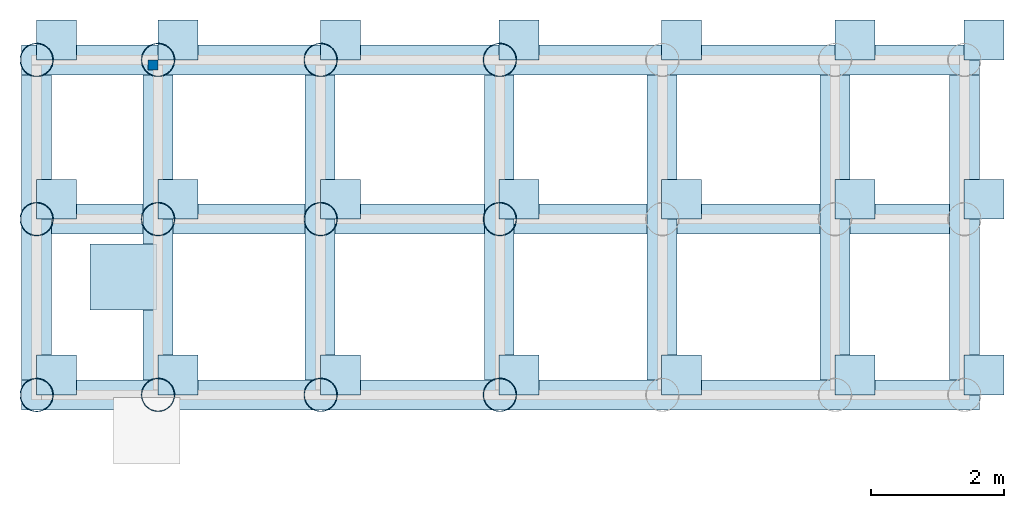
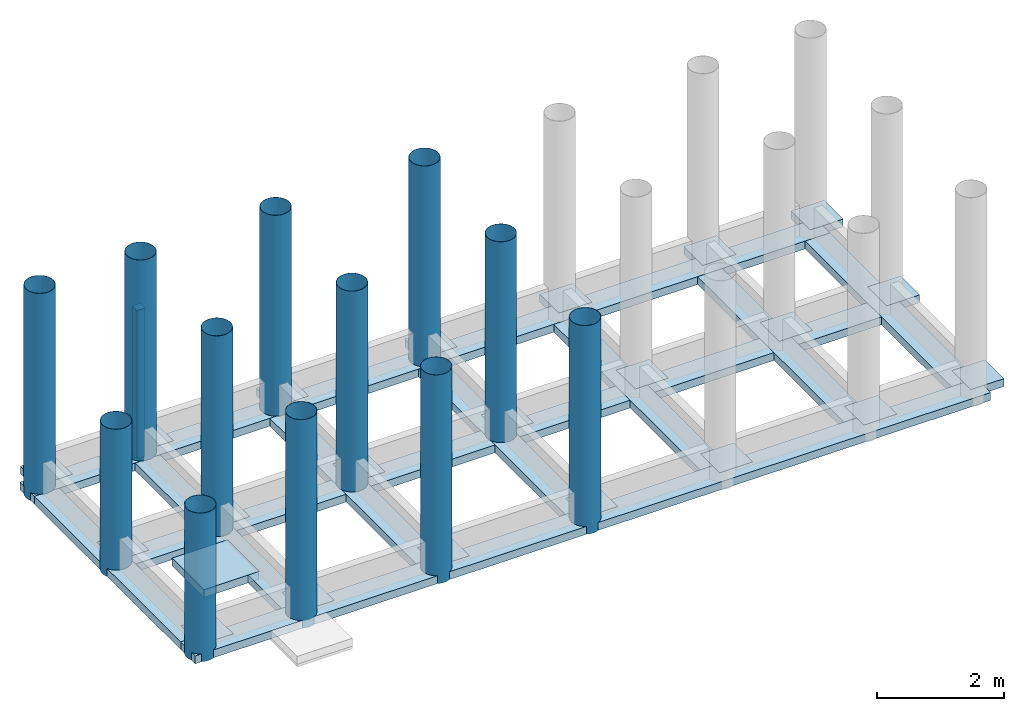
# One storey, part 1 of 2: 33 footings, 13 columns.
"""IFC4 building model written with IfcOpenShell, lengths in millimetres."""

from ifc_helpers import new_model, entity, si_unit, converted_unit, frame, origin_with_axes, origin_2d_with_axis, place, context, subcontext, project, spatial, line, indexed_curve, rectangle, hollow_circle, outline, extrude, material, layer, layer_set, layer_usage, material_profile, profile_set, profile_usage, type_object, element, save


model = new_model("IFC4")

# Units and contexts
model_context = context("Model", 3, precision=1e-05, world=origin_with_axes())
plan_context = context("Plan", 2, precision=1e-05, world=origin_2d_with_axis())
body_context = subcontext(model_context, "Body", "Model", "MODEL_VIEW")
ifc_project = project(units=[si_unit("AREAUNIT", "SQUARE_METRE"), si_unit("VOLUMEUNIT", "CUBIC_METRE"), si_unit("LENGTHUNIT", "METRE", prefix="MILLI"), converted_unit("PLANEANGLEUNIT", "degree", entity("IfcReal", 0.0174532925199433), si_unit("PLANEANGLEUNIT", "RADIAN"), dimensions=[0, 0, 0, 0, 0, 0, 0])], contexts=[model_context, plan_context])

# Site, building, storey
site_placement = place(None, frame((-860.053181648254, 6515.22541046143, 2.98023223876953e-05), z_axis=(0.0, 0.0, 1.0), x_axis=(7.54979012640431e-08, -0.999999999999997, 0.0)))
site = spatial("IfcSite", under=ifc_project, at=site_placement)
building_placement = place(site_placement, frame((0.0, 0.0, 0.0), z_axis=(0.0, 0.0, 1.0), x_axis=(1.0, -1.32348898008484e-23, 0.0)))
building = spatial("IfcBuilding", under=site, at=building_placement, Name="Building")
storey_placement = place(building_placement, frame((0.222206115722656, -1.67760250135984e-08, -750.000089406967), z_axis=(0.0, 0.0, 1.0), x_axis=(7.54979012640431e-08, 0.999999999999997, 0.0)))
storey = spatial("IfcBuildingStorey", under=building, at=storey_placement, Name="FOUNDATION")

# Footings
ifc_material = material(Name="Mass Concrete", Category="Concrete")
ifc_layer_1 = layer(ifc_material, 150.0, Name="Footing Layer", Category="Structure", Priority=1)
ifc_layer_set_1 = layer_set([ifc_layer_1], Name="WALL_FND_FTG_1LYR")
ifc_layer_usage_1 = layer_usage(ifc_layer_set_1, "AXIS3", "POSITIVE", 0.0)
footing_type = type_object("IfcFootingType", Name="FTG450x150", PredefinedType="STRIP_FOOTING", material=ifc_layer_set_1)
footing_1_placement = place(storey_placement, frame((124.997615814208, -549.653530120853, -149.999976158142), z_axis=(0.0, 0.0, 1.0), x_axis=(1.0, 1.32348898008484e-23, 0.0)))
element("IfcFooting", 1, at=footing_1_placement, inside=storey, type_object=footing_type, material=ifc_layer_usage_1, PredefinedType="STRIP_FOOTING", context=body_context, shape_type="SweptSolid", body=[
    extrude(outline(indexed_curve([(14205.0037384033, 149.991720914841), (14205.0037384033, -300.007820129395), (-225.000858306885, -300.007820129395), (-225.000858306885, 149.991720914841)], segments=[line(3, 2), line(2, 1), line(1, 4), line(4, 3)], self_intersect=False)), None, (0.0, 0.0, 1.0), 150.0),
])
ifc_layer_usage_2 = layer_usage(ifc_layer_set_1, "AXIS3", "POSITIVE", 0.0)
footing_2_placement = place(storey_placement, frame((124.997615814208, -2949.6774673462, -149.999976158142), z_axis=(0.0, 0.0, 1.0), x_axis=(1.0, 1.32348898008484e-23, 0.0)))
element("IfcFooting", 2, at=footing_2_placement, inside=storey, type_object=footing_type, material=ifc_layer_usage_2, Name="FLR150", PredefinedType="STRIP_FOOTING", context=body_context, shape_type="SweptSolid", body=[
    extrude(outline(indexed_curve([(13755.0058364868, 149.991720914841), (13755.0058364868, -300.007820129395), (224.997639656067, -300.007820129395), (224.997639656067, 149.991720914841)], segments=[line(3, 2), line(2, 1), line(1, 4), line(4, 3)], self_intersect=False)), None, (0.0, 0.0, 1.0), 150.0),
])
ifc_layer_usage_3 = layer_usage(ifc_layer_set_1, "AXIS3", "POSITIVE", 0.0)
footing_3_placement = place(storey_placement, frame((49.9976277351375, -5898.65279197693, -149.999976158142), z_axis=(0.0, 0.0, 1.0), x_axis=(1.0, 1.32348898008484e-23, 0.0)))
element("IfcFooting", 3, at=footing_3_placement, inside=storey, type_object=footing_type, material=ifc_layer_usage_3, PredefinedType="STRIP_FOOTING", context=body_context, shape_type="SweptSolid", body=[
    extrude(outline(indexed_curve([(299.997597932816, 5048.99168014526), (299.997597932816, 449.19490814209), (-150.000870227814, 449.19490814209), (-150.000870227814, 5048.99168014526)], segments=[line(3, 2), line(2, 1), line(1, 4), line(4, 3)], self_intersect=False)), None, (0.0, 0.0, 1.0), 150.0),
])
ifc_layer_usage_4 = layer_usage(ifc_layer_set_1, "AXIS3", "POSITIVE", 0.0)
footing_4_placement = place(storey_placement, frame((1880.00190258026, -5898.65279197693, -149.999976158142), z_axis=(0.0, 0.0, 1.0), x_axis=(1.0, 1.32348898008484e-23, 0.0)))
element("IfcFooting", 4, at=footing_4_placement, inside=storey, type_object=footing_type, material=ifc_layer_usage_4, PredefinedType="STRIP_FOOTING", context=body_context, shape_type="SweptSolid", body=[
    extrude(outline(indexed_curve([(299.997597932816, 5048.99168014526), (299.997597932816, 449.999570846558), (-150.000870227814, 449.999570846558), (-150.000870227814, 5048.99168014526)], segments=[line(3, 2), line(2, 1), line(1, 4), line(4, 3)], self_intersect=False)), None, (0.0, 0.0, 1.0), 150.0),
])
ifc_layer_usage_5 = layer_usage(ifc_layer_set_1, "AXIS3", "POSITIVE", 0.0)
footing_5_placement = place(storey_placement, frame((4320.84238529205, -5898.65279197693, -149.999976158142), z_axis=(0.0, 0.0, 1.0), x_axis=(1.0, 1.32348898008484e-23, 0.0)))
element("IfcFooting", 5, at=footing_5_placement, inside=storey, type_object=footing_type, material=ifc_layer_usage_5, PredefinedType="STRIP_FOOTING", context=body_context, shape_type="SweptSolid", body=[
    extrude(outline(indexed_curve([(-150.000870227814, 449.999570846558), (299.997597932816, 449.999570846558), (299.997597932816, 5048.99168014526), (-150.000870227814, 5048.99168014526)], segments=[line(3, 2), line(2, 1), line(1, 4), line(4, 3)], self_intersect=False)), None, (0.0, 0.0, 1.0), 150.0),
])
ifc_layer_usage_6 = layer_usage(ifc_layer_set_1, "AXIS3", "POSITIVE", 0.0)
footing_6_placement = place(storey_placement, frame((7020.84076404571, -5898.65279197693, -149.999976158142), z_axis=(0.0, 0.0, 1.0), x_axis=(1.0, 1.32348898008484e-23, 0.0)))
element("IfcFooting", 6, at=footing_6_placement, inside=storey, type_object=footing_type, material=ifc_layer_usage_6, PredefinedType="STRIP_FOOTING", context=body_context, shape_type="SweptSolid", body=[
    extrude(outline(indexed_curve([(-150.000870227814, 449.999570846558), (299.997597932816, 449.999570846558), (299.997597932816, 5048.99168014526), (-150.000870227814, 5048.99168014526)], segments=[line(3, 2), line(2, 1), line(1, 4), line(4, 3)], self_intersect=False)), None, (0.0, 0.0, 1.0), 150.0),
])
ifc_layer_usage_7 = layer_usage(ifc_layer_set_1, "AXIS3", "POSITIVE", 0.0)
footing_7_placement = place(storey_placement, frame((9470.83961963653, -5898.65279197693, -149.999976158142), z_axis=(0.0, 0.0, 1.0), x_axis=(1.0, 1.32348898008484e-23, 0.0)))
element("IfcFooting", 7, at=footing_7_placement, inside=storey, type_object=footing_type, material=ifc_layer_usage_7, PredefinedType="STRIP_FOOTING", context=body_context, shape_type="SweptSolid", body=[
    extrude(outline(indexed_curve([(-150.000870227814, 449.999570846558), (299.997597932816, 449.999570846558), (299.997597932816, 5048.99168014526), (-150.000870227814, 5048.99168014526)], segments=[line(3, 2), line(2, 1), line(1, 4), line(4, 3)], self_intersect=False)), None, (0.0, 0.0, 1.0), 150.0),
])
ifc_layer_usage_8 = layer_usage(ifc_layer_set_1, "AXIS3", "POSITIVE", 0.0)
footing_8_placement = place(storey_placement, frame((12080.0048112869, -5898.65279197693, -149.999976158142), z_axis=(0.0, 0.0, 1.0), x_axis=(1.0, 1.32348898008484e-23, 0.0)))
element("IfcFooting", 8, at=footing_8_placement, inside=storey, type_object=footing_type, material=ifc_layer_usage_8, PredefinedType="STRIP_FOOTING", context=body_context, shape_type="SweptSolid", body=[
    extrude(outline(indexed_curve([(-150.000870227814, 449.999570846558), (299.997597932816, 449.999570846558), (299.997597932816, 5048.99168014526), (-150.000870227814, 5048.99168014526)], segments=[line(3, 2), line(2, 1), line(1, 4), line(4, 3)], self_intersect=False)), None, (0.0, 0.0, 1.0), 150.0),
])
ifc_layer_usage_9 = layer_usage(ifc_layer_set_1, "AXIS3", "POSITIVE", 0.0)
footing_9_placement = place(storey_placement, frame((14030.0036668777, -5898.65279197693, -149.999976158142), z_axis=(0.0, 0.0, 1.0), x_axis=(1.0, 1.32348898008484e-23, 0.0)))
element("IfcFooting", 9, at=footing_9_placement, inside=storey, type_object=footing_type, material=ifc_layer_usage_9, Name="FLR150", PredefinedType="STRIP_FOOTING", context=body_context, shape_type="SweptSolid", body=[
    extrude(outline(indexed_curve([(-150.000870227814, 449.999570846558), (299.997597932816, 449.999570846558), (299.997597932816, 5048.99168014526), (-150.000870227814, 5048.99168014526)], segments=[line(3, 2), line(2, 1), line(1, 4), line(4, 3)], self_intersect=False)), None, (0.0, 0.0, 1.0), 150.0),
])
ifc_layer_usage_10 = layer_usage(ifc_layer_set_1, "AXIS3", "POSITIVE", 0.0)
footing_10_placement = place(storey_placement, frame((124.997615814208, -5599.449634552, -149.999976158142), z_axis=(0.0, 0.0, 1.0), x_axis=(1.0, 1.32348898008484e-23, 0.0)))
element("IfcFooting", 10, at=footing_10_placement, inside=storey, type_object=footing_type, material=ifc_layer_usage_10, PredefinedType="STRIP_FOOTING", context=body_context, shape_type="SweptSolid", body=[
    extrude(outline(indexed_curve([(-225.000858306885, -300.007820129395), (14205.0037384033, -300.007820129395), (14205.0037384033, 149.991720914841), (-225.000858306885, 149.991720914841)], segments=[line(3, 2), line(2, 1), line(1, 4), line(4, 3)], self_intersect=False)), None, (0.0, 0.0, 1.0), 150.0),
])
ifc_layer_usage_11 = layer_usage(ifc_layer_set_1, "AXIS2", "POSITIVE", 0.0)
footing_11_placement = place(storey_placement, frame((929.933577775955, -4396.21543884278, -149.999976158142), z_axis=(0.0, 0.0, 1.0), x_axis=(1.0, 1.32348898008484e-23, 0.0)))
element("IfcFooting", 11, at=footing_11_placement, inside=storey, type_object=footing_type, material=ifc_layer_usage_11, Name="FTG450x150", context=body_context, shape_type="SweptSolid", body=[
    extrude(outline(indexed_curve([(0.0, 0.0), (1000.0, 0.0), (1000.0, 1000.0), (0.0, 1000.0), (0.0, 0.0)])), None, (0.0, 0.0, 1.0), 150.0),
])
ifc_layer_usage_12 = layer_usage(ifc_layer_set_1, "AXIS2", "POSITIVE", 0.0)
footing_12_placement = place(storey_placement, frame((929.933577775955, -4396.21543884278, -149.999976158142), z_axis=(0.0, 0.0, 1.0), x_axis=(1.0, 1.32348898008484e-23, 0.0)))
element("IfcFooting", 12, at=footing_12_placement, inside=storey, type_object=footing_type, material=ifc_layer_usage_12, Name="FTG450x150", context=body_context, shape_type="SweptSolid", body=[
    extrude(outline(indexed_curve([(0.0, 0.0), (1000.0, 0.0), (1000.0, 1000.0), (0.0, 1000.0), (0.0, 0.0)])), None, (0.0, 0.0, 1.0), 150.0),
])
ifc_layer_2 = layer(ifc_material, 150.0, Name="Column Footing Layer", Category="Structure", Priority=1)
ifc_layer_set_2 = layer_set([ifc_layer_2], Name="FTG_COL_1LYR")
ifc_layer_usage_13 = layer_usage(ifc_layer_set_2, "AXIS3", "POSITIVE", 0.0)
slab_type = type_object("IfcSlabType", Name="FLR_150", PredefinedType="NOTDEFINED", material=ifc_layer_set_2)
footing_13_placement = place(storey_placement, frame((124.994397163391, -5674.44968223572, -149.999976158142), z_axis=(0.0, 0.0, 1.0), x_axis=(1.0, 1.32348898008484e-23, 0.0)))
element("IfcFooting", 13, at=footing_13_placement, inside=storey, type_object=slab_type, material=ifc_layer_usage_13, PredefinedType="PAD_FOOTING", context=body_context, shape_type="SweptSolid", body=[
    extrude(outline(indexed_curve([(0.0, 0.0), (600.000023841858, 0.0), (600.000023841858, 600.000023841858), (0.0, 600.000023841858)], segments=[line(3, 2), line(2, 1), line(1, 4), line(4, 3)], self_intersect=False)), None, (0.0, 0.0, 1.0), 150.0),
])
ifc_layer_usage_14 = layer_usage(ifc_layer_set_2, "AXIS3", "POSITIVE", 0.0)
footing_14_placement = place(storey_placement, frame((124.994397163391, -3024.6856212616, -149.999976158142), z_axis=(0.0, 0.0, 1.0), x_axis=(1.0, 1.32348898008484e-23, 0.0)))
element("IfcFooting", 14, at=footing_14_placement, inside=storey, type_object=slab_type, material=ifc_layer_usage_14, PredefinedType="PAD_FOOTING", context=body_context, shape_type="SweptSolid", body=[
    extrude(outline(indexed_curve([(0.0, 0.0), (600.000023841858, 0.0), (600.000023841858, 600.000023841858), (0.0, 600.000023841858)], segments=[line(3, 2), line(2, 1), line(1, 4), line(4, 3)], self_intersect=False)), None, (0.0, 0.0, 1.0), 150.0),
])
ifc_layer_usage_15 = layer_usage(ifc_layer_set_2, "AXIS3", "POSITIVE", 0.0)
footing_15_placement = place(storey_placement, frame((124.994397163391, -624.653816223148, -149.999976158142), z_axis=(0.0, 0.0, 1.0), x_axis=(1.0, 1.32348898008484e-23, 0.0)))
element("IfcFooting", 15, at=footing_15_placement, inside=storey, type_object=slab_type, material=ifc_layer_usage_15, PredefinedType="PAD_FOOTING", context=body_context, shape_type="SweptSolid", body=[
    extrude(outline(indexed_curve([(0.0, 0.0), (600.000023841858, 0.0), (600.000023841858, 600.000023841858), (0.0, 600.000023841858)], segments=[line(3, 2), line(2, 1), line(1, 4), line(4, 3)], self_intersect=False)), None, (0.0, 0.0, 1.0), 150.0),
])
ifc_layer_usage_16 = layer_usage(ifc_layer_set_2, "AXIS3", "POSITIVE", 0.0)
footing_16_placement = place(storey_placement, frame((1956.27570152283, -5674.44968223572, -149.999976158142), z_axis=(0.0, 0.0, 1.0), x_axis=(1.0, 1.32348898008484e-23, 0.0)))
element("IfcFooting", 16, at=footing_16_placement, inside=storey, type_object=slab_type, material=ifc_layer_usage_16, PredefinedType="PAD_FOOTING", context=body_context, shape_type="SweptSolid", body=[
    extrude(outline(indexed_curve([(0.0, 0.0), (600.000023841858, 0.0), (600.000023841858, 600.000023841858), (0.0, 600.000023841858)], segments=[line(3, 2), line(2, 1), line(1, 4), line(4, 3)], self_intersect=False)), None, (0.0, 0.0, 1.0), 150.0),
])
ifc_layer_usage_17 = layer_usage(ifc_layer_set_2, "AXIS3", "POSITIVE", 0.0)
footing_17_placement = place(storey_placement, frame((1956.27570152283, -3024.6856212616, -149.999976158142), z_axis=(0.0, 0.0, 1.0), x_axis=(1.0, 1.32348898008484e-23, 0.0)))
element("IfcFooting", 17, at=footing_17_placement, inside=storey, type_object=slab_type, material=ifc_layer_usage_17, PredefinedType="PAD_FOOTING", context=body_context, shape_type="SweptSolid", body=[
    extrude(outline(indexed_curve([(0.0, 0.0), (600.000023841858, 0.0), (600.000023841858, 600.000023841858), (0.0, 600.000023841858)], segments=[line(3, 2), line(2, 1), line(1, 4), line(4, 3)], self_intersect=False)), None, (0.0, 0.0, 1.0), 150.0),
])
ifc_layer_usage_18 = layer_usage(ifc_layer_set_2, "AXIS3", "POSITIVE", 0.0)
footing_18_placement = place(storey_placement, frame((1956.27570152283, -624.653816223148, -149.999976158142), z_axis=(0.0, 0.0, 1.0), x_axis=(1.0, 1.32348898008484e-23, 0.0)))
element("IfcFooting", 18, at=footing_18_placement, inside=storey, type_object=slab_type, material=ifc_layer_usage_18, PredefinedType="PAD_FOOTING", context=body_context, shape_type="SweptSolid", body=[
    extrude(outline(indexed_curve([(0.0, 0.0), (600.000023841858, 0.0), (600.000023841858, 600.000023841858), (0.0, 600.000023841858)], segments=[line(3, 2), line(2, 1), line(1, 4), line(4, 3)], self_intersect=False)), None, (0.0, 0.0, 1.0), 150.0),
])
ifc_layer_usage_19 = layer_usage(ifc_layer_set_2, "AXIS3", "POSITIVE", 0.0)
footing_19_placement = place(storey_placement, frame((4405.00128269195, -5674.44968223572, -149.999976158142), z_axis=(0.0, 0.0, 1.0), x_axis=(1.0, 1.32348898008484e-23, 0.0)))
element("IfcFooting", 19, at=footing_19_placement, inside=storey, type_object=slab_type, material=ifc_layer_usage_19, PredefinedType="PAD_FOOTING", context=body_context, shape_type="SweptSolid", body=[
    extrude(outline(indexed_curve([(0.0, 0.0), (600.000023841858, 0.0), (600.000023841858, 600.000023841858), (0.0, 600.000023841858)], segments=[line(3, 2), line(2, 1), line(1, 4), line(4, 3)], self_intersect=False)), None, (0.0, 0.0, 1.0), 150.0),
])
ifc_layer_usage_20 = layer_usage(ifc_layer_set_2, "AXIS3", "POSITIVE", 0.0)
footing_20_placement = place(storey_placement, frame((4405.00128269195, -3024.6856212616, -149.999976158142), z_axis=(0.0, 0.0, 1.0), x_axis=(1.0, 1.32348898008484e-23, 0.0)))
element("IfcFooting", 20, at=footing_20_placement, inside=storey, type_object=slab_type, material=ifc_layer_usage_20, PredefinedType="PAD_FOOTING", context=body_context, shape_type="SweptSolid", body=[
    extrude(outline(indexed_curve([(0.0, 0.0), (600.000023841858, 0.0), (600.000023841858, 600.000023841858), (0.0, 600.000023841858)], segments=[line(3, 2), line(2, 1), line(1, 4), line(4, 3)], self_intersect=False)), None, (0.0, 0.0, 1.0), 150.0),
])
ifc_layer_usage_21 = layer_usage(ifc_layer_set_2, "AXIS3", "POSITIVE", 0.0)
footing_21_placement = place(storey_placement, frame((4405.00128269195, -624.653816223148, -149.999976158142), z_axis=(0.0, 0.0, 1.0), x_axis=(1.0, 1.32348898008484e-23, 0.0)))
element("IfcFooting", 21, at=footing_21_placement, inside=storey, type_object=slab_type, material=ifc_layer_usage_21, PredefinedType="PAD_FOOTING", context=body_context, shape_type="SweptSolid", body=[
    extrude(outline(indexed_curve([(0.0, 0.0), (600.000023841858, 0.0), (600.000023841858, 600.000023841858), (0.0, 600.000023841858)], segments=[line(3, 2), line(2, 1), line(1, 4), line(4, 3)], self_intersect=False)), None, (0.0, 0.0, 1.0), 150.0),
])
ifc_layer_usage_22 = layer_usage(ifc_layer_set_2, "AXIS3", "POSITIVE", 0.0)
footing_22_placement = place(storey_placement, frame((7095.83914279937, -5674.44968223572, -149.999976158142), z_axis=(0.0, 0.0, 1.0), x_axis=(1.0, 1.32348898008484e-23, 0.0)))
element("IfcFooting", 22, at=footing_22_placement, inside=storey, type_object=slab_type, material=ifc_layer_usage_22, PredefinedType="PAD_FOOTING", context=body_context, shape_type="SweptSolid", body=[
    extrude(outline(indexed_curve([(0.0, 0.0), (600.000023841858, 0.0), (600.000023841858, 600.000023841858), (0.0, 600.000023841858)], segments=[line(3, 2), line(2, 1), line(1, 4), line(4, 3)], self_intersect=False)), None, (0.0, 0.0, 1.0), 150.0),
])
ifc_layer_usage_23 = layer_usage(ifc_layer_set_2, "AXIS3", "POSITIVE", 0.0)
footing_23_placement = place(storey_placement, frame((7095.83914279937, -3024.6856212616, -149.999976158142), z_axis=(0.0, 0.0, 1.0), x_axis=(1.0, 1.32348898008484e-23, 0.0)))
element("IfcFooting", 23, at=footing_23_placement, inside=storey, type_object=slab_type, material=ifc_layer_usage_23, PredefinedType="PAD_FOOTING", context=body_context, shape_type="SweptSolid", body=[
    extrude(outline(indexed_curve([(0.0, 0.0), (600.000023841858, 0.0), (600.000023841858, 600.000023841858), (0.0, 600.000023841858)], segments=[line(3, 2), line(2, 1), line(1, 4), line(4, 3)], self_intersect=False)), None, (0.0, 0.0, 1.0), 150.0),
])
ifc_layer_usage_24 = layer_usage(ifc_layer_set_2, "AXIS3", "POSITIVE", 0.0)
footing_24_placement = place(storey_placement, frame((7095.83914279937, -624.653816223148, -149.999976158142), z_axis=(0.0, 0.0, 1.0), x_axis=(1.0, 1.32348898008484e-23, 0.0)))
element("IfcFooting", 24, at=footing_24_placement, inside=storey, type_object=slab_type, material=ifc_layer_usage_24, PredefinedType="PAD_FOOTING", context=body_context, shape_type="SweptSolid", body=[
    extrude(outline(indexed_curve([(0.0, 0.0), (600.000023841858, 0.0), (600.000023841858, 600.000023841858), (0.0, 600.000023841858)], segments=[line(3, 2), line(2, 1), line(1, 4), line(4, 3)], self_intersect=False)), None, (0.0, 0.0, 1.0), 150.0),
])
ifc_layer_usage_25 = layer_usage(ifc_layer_set_2, "AXIS3", "POSITIVE", 0.0)
footing_25_placement = place(storey_placement, frame((9541.80443286896, -5674.44968223572, -149.999976158142), z_axis=(0.0, 0.0, 1.0), x_axis=(1.0, 1.32348898008484e-23, 0.0)))
element("IfcFooting", 25, at=footing_25_placement, inside=storey, type_object=slab_type, material=ifc_layer_usage_25, PredefinedType="PAD_FOOTING", context=body_context, shape_type="SweptSolid", body=[
    extrude(outline(indexed_curve([(0.0, 0.0), (600.000023841858, 0.0), (600.000023841858, 600.000023841858), (0.0, 600.000023841858)], segments=[line(3, 2), line(2, 1), line(1, 4), line(4, 3)], self_intersect=False)), None, (0.0, 0.0, 1.0), 150.0),
])
ifc_layer_usage_26 = layer_usage(ifc_layer_set_2, "AXIS3", "POSITIVE", 0.0)
footing_26_placement = place(storey_placement, frame((9541.80443286896, -3024.6856212616, -149.999976158142), z_axis=(0.0, 0.0, 1.0), x_axis=(1.0, 1.32348898008484e-23, 0.0)))
element("IfcFooting", 26, at=footing_26_placement, inside=storey, type_object=slab_type, material=ifc_layer_usage_26, PredefinedType="PAD_FOOTING", context=body_context, shape_type="SweptSolid", body=[
    extrude(outline(indexed_curve([(0.0, 0.0), (600.000023841858, 0.0), (600.000023841858, 600.000023841858), (0.0, 600.000023841858)], segments=[line(3, 2), line(2, 1), line(1, 4), line(4, 3)], self_intersect=False)), None, (0.0, 0.0, 1.0), 150.0),
])
ifc_layer_usage_27 = layer_usage(ifc_layer_set_2, "AXIS3", "POSITIVE", 0.0)
footing_27_placement = place(storey_placement, frame((9541.80443286896, -624.653816223148, -149.999976158142), z_axis=(0.0, 0.0, 1.0), x_axis=(1.0, 1.32348898008484e-23, 0.0)))
element("IfcFooting", 27, at=footing_27_placement, inside=storey, type_object=slab_type, material=ifc_layer_usage_27, PredefinedType="PAD_FOOTING", context=body_context, shape_type="SweptSolid", body=[
    extrude(outline(indexed_curve([(0.0, 0.0), (600.000023841858, 0.0), (600.000023841858, 600.000023841858), (0.0, 600.000023841858)], segments=[line(3, 2), line(2, 1), line(1, 4), line(4, 3)], self_intersect=False)), None, (0.0, 0.0, 1.0), 150.0),
])
ifc_layer_usage_28 = layer_usage(ifc_layer_set_2, "AXIS3", "POSITIVE", 0.0)
footing_28_placement = place(storey_placement, frame((12156.2777757645, -5674.44968223572, -149.999976158142), z_axis=(0.0, 0.0, 1.0), x_axis=(1.0, 1.32348898008484e-23, 0.0)))
element("IfcFooting", 28, at=footing_28_placement, inside=storey, type_object=slab_type, material=ifc_layer_usage_28, PredefinedType="PAD_FOOTING", context=body_context, shape_type="SweptSolid", body=[
    extrude(outline(indexed_curve([(0.0, 0.0), (600.000023841858, 0.0), (600.000023841858, 600.000023841858), (0.0, 600.000023841858)], segments=[line(3, 2), line(2, 1), line(1, 4), line(4, 3)], self_intersect=False)), None, (0.0, 0.0, 1.0), 150.0),
])
ifc_layer_usage_29 = layer_usage(ifc_layer_set_2, "AXIS3", "POSITIVE", 0.0)
footing_29_placement = place(storey_placement, frame((12156.2777757645, -3024.6856212616, -149.999976158142), z_axis=(0.0, 0.0, 1.0), x_axis=(1.0, 1.32348898008484e-23, 0.0)))
element("IfcFooting", 29, at=footing_29_placement, inside=storey, type_object=slab_type, material=ifc_layer_usage_29, PredefinedType="PAD_FOOTING", context=body_context, shape_type="SweptSolid", body=[
    extrude(outline(indexed_curve([(0.0, 0.0), (600.000023841858, 0.0), (600.000023841858, 600.000023841858), (0.0, 600.000023841858)], segments=[line(3, 2), line(2, 1), line(1, 4), line(4, 3)], self_intersect=False)), None, (0.0, 0.0, 1.0), 150.0),
])
ifc_layer_usage_30 = layer_usage(ifc_layer_set_2, "AXIS3", "POSITIVE", 0.0)
footing_30_placement = place(storey_placement, frame((12156.2777757645, -624.653816223148, -149.999976158142), z_axis=(0.0, 0.0, 1.0), x_axis=(1.0, 1.32348898008484e-23, 0.0)))
element("IfcFooting", 30, at=footing_30_placement, inside=storey, type_object=slab_type, material=ifc_layer_usage_30, PredefinedType="PAD_FOOTING", context=body_context, shape_type="SweptSolid", body=[
    extrude(outline(indexed_curve([(0.0, 0.0), (600.000023841858, 0.0), (600.000023841858, 600.000023841858), (0.0, 600.000023841858)], segments=[line(3, 2), line(2, 1), line(1, 4), line(4, 3)], self_intersect=False)), None, (0.0, 0.0, 1.0), 150.0),
])
ifc_layer_usage_31 = layer_usage(ifc_layer_set_2, "AXIS3", "POSITIVE", 0.0)
footing_31_placement = place(storey_placement, frame((14100.9684801102, -5674.44968223572, -149.999976158142), z_axis=(0.0, 0.0, 1.0), x_axis=(1.0, 1.32348898008484e-23, 0.0)))
element("IfcFooting", 31, at=footing_31_placement, inside=storey, type_object=slab_type, material=ifc_layer_usage_31, PredefinedType="PAD_FOOTING", context=body_context, shape_type="SweptSolid", body=[
    extrude(outline(indexed_curve([(0.0, 0.0), (600.000023841858, 0.0), (600.000023841858, 600.000023841858), (0.0, 600.000023841858)], segments=[line(3, 2), line(2, 1), line(1, 4), line(4, 3)], self_intersect=False)), None, (0.0, 0.0, 1.0), 150.0),
])
ifc_layer_usage_32 = layer_usage(ifc_layer_set_2, "AXIS3", "POSITIVE", 0.0)
footing_32_placement = place(storey_placement, frame((14100.9684801102, -3024.6856212616, -149.999976158142), z_axis=(0.0, 0.0, 1.0), x_axis=(1.0, 1.32348898008484e-23, 0.0)))
element("IfcFooting", 32, at=footing_32_placement, inside=storey, type_object=slab_type, material=ifc_layer_usage_32, PredefinedType="PAD_FOOTING", context=body_context, shape_type="SweptSolid", body=[
    extrude(outline(indexed_curve([(0.0, 0.0), (600.000023841858, 0.0), (600.000023841858, 600.000023841858), (0.0, 600.000023841858)], segments=[line(3, 2), line(2, 1), line(1, 4), line(4, 3)], self_intersect=False)), None, (0.0, 0.0, 1.0), 150.0),
])
ifc_layer_usage_33 = layer_usage(ifc_layer_set_2, "AXIS3", "POSITIVE", 0.0)
footing_33_placement = place(storey_placement, frame((14100.9684801102, -624.653816223148, -149.999976158142), z_axis=(0.0, 0.0, 1.0), x_axis=(1.0, 1.32348898008484e-23, 0.0)))
element("IfcFooting", 33, at=footing_33_placement, inside=storey, type_object=slab_type, material=ifc_layer_usage_33, Name="FLR250", PredefinedType="PAD_FOOTING", context=body_context, shape_type="SweptSolid", body=[
    extrude(outline(indexed_curve([(0.0, 0.0), (600.000023841858, 0.0), (600.000023841858, 600.000023841858), (0.0, 600.000023841858)], segments=[line(3, 2), line(2, 1), line(1, 4), line(4, 3)], self_intersect=False)), None, (0.0, 0.0, 1.0), 150.0),
])

# Columns
ifc_material_profile = material_profile(ifc_material, rectangle(XDim=150.0, YDim=150.0), Name="Square Column", Category="Structure", Priority=1)
ifc_profile_set = profile_set([ifc_material_profile], Name="RC_COL_150x150")
ifc_profile_usage_1 = profile_usage(ifc_profile_set, cardinal=5)
column_type = type_object("IfcColumnType", Name="C1", PredefinedType="NOTDEFINED", material=ifc_profile_set)
column_1_placement = place(storey_placement, frame((124.994397163391, -5674.44968223572, -149.999976158142), z_axis=(0.0, 0.0, 1.0), x_axis=(1.0, 1.32348898008484e-23, 0.0)))
element("IfcColumn", 34, at=column_1_placement, inside=storey, type_object=column_type, material=ifc_profile_usage_1, Name="C1", context=body_context, shape_type="SweptSolid", body=[
    extrude(hollow_circle(Radius=250.0, WallThickness=5.0), origin_with_axes(), (0.0, 0.0, 1.0), 2850.00007361696),
])
ifc_profile_usage_2 = profile_usage(ifc_profile_set, cardinal=5)
column_2_placement = place(storey_placement, frame((124.994397163391, -3024.67775344849, -149.999976158142), z_axis=(0.0, 0.0, 1.0), x_axis=(1.0, 1.32348898008484e-23, 0.0)))
element("IfcColumn", 35, at=column_2_placement, inside=storey, type_object=column_type, material=ifc_profile_usage_2, Name="C1", context=body_context, shape_type="SweptSolid", body=[
    extrude(hollow_circle(Radius=250.0, WallThickness=5.0), origin_with_axes(), (0.0, 0.0, 1.0), 2850.00007361696),
])
ifc_profile_usage_3 = profile_usage(ifc_profile_set, cardinal=5)
column_3_placement = place(storey_placement, frame((124.994397163391, -626.263618469242, -149.999976158142), z_axis=(0.0, 0.0, 1.0), x_axis=(1.0, 1.32348898008484e-23, 0.0)))
element("IfcColumn", 36, at=column_3_placement, inside=storey, type_object=column_type, material=ifc_profile_usage_3, Name="C1", context=body_context, shape_type="SweptSolid", body=[
    extrude(hollow_circle(Radius=250.0, WallThickness=5.0), origin_with_axes(), (0.0, 0.0, 1.0), 4000.0),
])
ifc_profile_usage_4 = profile_usage(ifc_profile_set, cardinal=5)
column_4_placement = place(storey_placement, frame((1880.0003528595, -699.673175811771, -1.11022302462516e-13), z_axis=(0.0, 0.0, 1.0), x_axis=(1.0, 1.32348898008484e-23, 0.0)))
element("IfcColumn", 37, at=column_4_placement, inside=storey, type_object=column_type, material=ifc_profile_usage_4, Name="C1", context=body_context, shape_type="SweptSolid", body=[
    extrude(rectangle(XDim=150.0, YDim=150.0), origin_with_axes(), (0.0, 0.0, 1.0), 2850.00014305115),
])
ifc_profile_usage_5 = profile_usage(ifc_profile_set, cardinal=5)
column_5_placement = place(storey_placement, frame((1954.9515247345, -626.263618469242, -149.999976158142), z_axis=(0.0, 0.0, 1.0), x_axis=(1.0, 1.32348898008484e-23, 0.0)))
element("IfcColumn", 38, at=column_5_placement, inside=storey, type_object=column_type, material=ifc_profile_usage_5, Name="C1", context=body_context, shape_type="SweptSolid", body=[
    extrude(hollow_circle(Radius=250.0, WallThickness=5.0), origin_with_axes(), (0.0, 0.0, 1.0), 4000.0),
])
ifc_profile_usage_6 = profile_usage(ifc_profile_set, cardinal=5)
column_6_placement = place(storey_placement, frame((4404.9516916275, -626.263618469242, -149.999976158142), z_axis=(0.0, 0.0, 1.0), x_axis=(1.0, 1.32348898008484e-23, 0.0)))
element("IfcColumn", 39, at=column_6_placement, inside=storey, type_object=column_type, material=ifc_profile_usage_6, Name="C1", context=body_context, shape_type="SweptSolid", body=[
    extrude(hollow_circle(Radius=250.0, WallThickness=5.0), origin_with_axes(), (0.0, 0.0, 1.0), 4000.0),
])
ifc_profile_usage_7 = profile_usage(ifc_profile_set, cardinal=5)
column_7_placement = place(storey_placement, frame((7104.9553155899, -626.263618469242, -149.999976158142), z_axis=(0.0, 0.0, 1.0), x_axis=(1.0, 1.32348898008484e-23, 0.0)))
element("IfcColumn", 40, at=column_7_placement, inside=storey, type_object=column_type, material=ifc_profile_usage_7, Name="C1", context=body_context, shape_type="SweptSolid", body=[
    extrude(hollow_circle(Radius=250.0, WallThickness=5.0), origin_with_axes(), (0.0, 0.0, 1.0), 4000.0),
])
ifc_profile_usage_8 = profile_usage(ifc_profile_set, cardinal=5)
column_8_placement = place(storey_placement, frame((7105.04972934723, -5672.84035682678, -149.999976158142), z_axis=(0.0, 0.0, 1.0), x_axis=(1.0, 1.32348898008484e-23, 0.0)))
element("IfcColumn", 41, at=column_8_placement, inside=storey, type_object=column_type, material=ifc_profile_usage_8, Name="C1", context=body_context, shape_type="SweptSolid", body=[
    extrude(hollow_circle(Radius=250.0, WallThickness=5.0), origin_with_axes(), (0.0, 0.0, 1.0), 4000.0),
])
ifc_profile_usage_9 = profile_usage(ifc_profile_set, cardinal=5)
column_9_placement = place(storey_placement, frame((4405.00175952911, -5672.84035682678, -149.999976158142), z_axis=(0.0, 0.0, 1.0), x_axis=(1.0, 1.32348898008484e-23, 0.0)))
element("IfcColumn", 42, at=column_9_placement, inside=storey, type_object=column_type, material=ifc_profile_usage_9, Name="C1", context=body_context, shape_type="SweptSolid", body=[
    extrude(hollow_circle(Radius=250.0, WallThickness=5.0), origin_with_axes(), (0.0, 0.0, 1.0), 4000.0),
])
ifc_profile_usage_10 = profile_usage(ifc_profile_set, cardinal=5)
column_10_placement = place(storey_placement, frame((1955.05154132843, -5672.84035682678, -149.999976158142), z_axis=(0.0, 0.0, 1.0), x_axis=(1.0, 1.32348898008484e-23, 0.0)))
element("IfcColumn", 43, at=column_10_placement, inside=storey, type_object=column_type, material=ifc_profile_usage_10, Name="C1", context=body_context, shape_type="SweptSolid", body=[
    extrude(hollow_circle(Radius=250.0, WallThickness=5.0), origin_with_axes(), (0.0, 0.0, 1.0), 4000.0),
])
ifc_profile_usage_11 = profile_usage(ifc_profile_set, cardinal=5)
column_11_placement = place(storey_placement, frame((1955.05154132843, -3024.67823028565, -149.999976158142), z_axis=(0.0, 0.0, 1.0), x_axis=(1.0, 1.32348898008484e-23, 0.0)))
element("IfcColumn", 44, at=column_11_placement, inside=storey, type_object=column_type, material=ifc_profile_usage_11, Name="C1", context=body_context, shape_type="SweptSolid", body=[
    extrude(hollow_circle(Radius=250.0, WallThickness=5.0), origin_with_axes(), (0.0, 0.0, 1.0), 4000.0),
])
ifc_profile_usage_12 = profile_usage(ifc_profile_set, cardinal=5)
column_12_placement = place(storey_placement, frame((4405.00128269195, -3024.67823028565, -149.999976158142), z_axis=(0.0, 0.0, 1.0), x_axis=(1.0, 1.32348898008484e-23, 0.0)))
element("IfcColumn", 45, at=column_12_placement, inside=storey, type_object=column_type, material=ifc_profile_usage_12, Name="C1", context=body_context, shape_type="SweptSolid", body=[
    extrude(hollow_circle(Radius=250.0, WallThickness=5.0), origin_with_axes(), (0.0, 0.0, 1.0), 4000.0),
])
ifc_profile_usage_13 = profile_usage(ifc_profile_set, cardinal=5)
column_13_placement = place(storey_placement, frame((7105.00204563141, -3024.67823028565, -149.999976158142), z_axis=(0.0, 0.0, 1.0), x_axis=(1.0, 1.32348898008484e-23, 0.0)))
element("IfcColumn", 46, at=column_13_placement, inside=storey, type_object=column_type, material=ifc_profile_usage_13, Name="C1", context=body_context, shape_type="SweptSolid", body=[
    extrude(hollow_circle(Radius=250.0, WallThickness=5.0), origin_with_axes(), (0.0, 0.0, 1.0), 4000.0),
])

save(model, "model.ifc")
